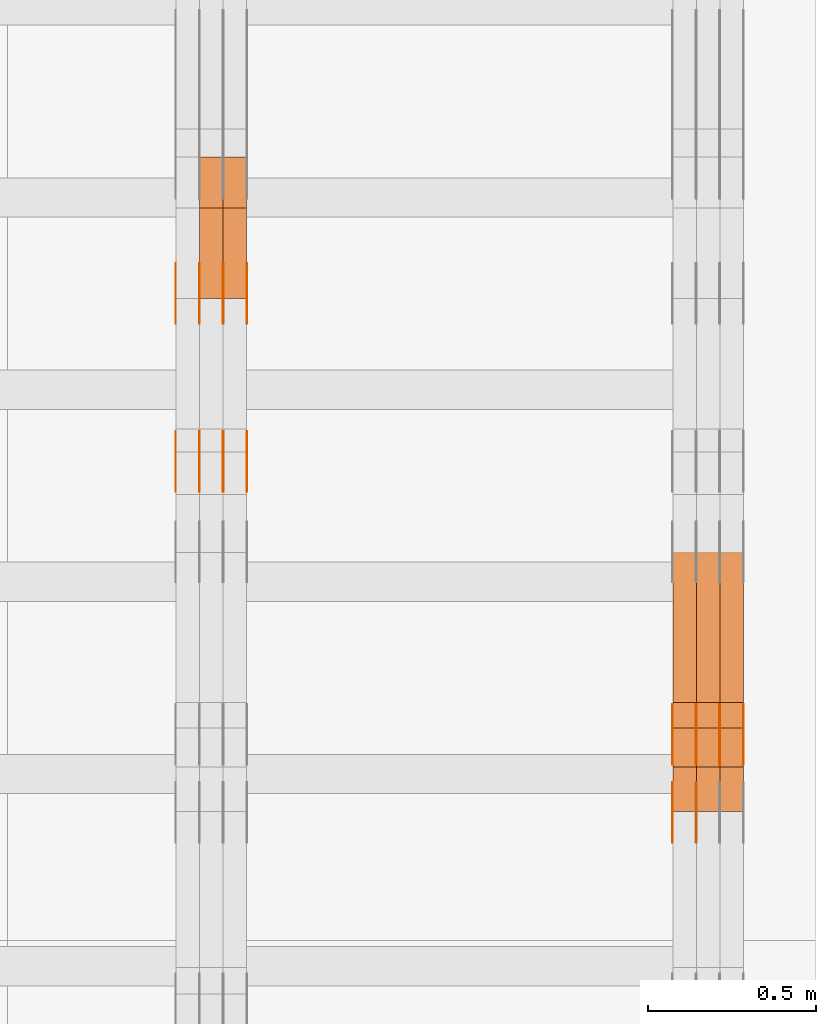
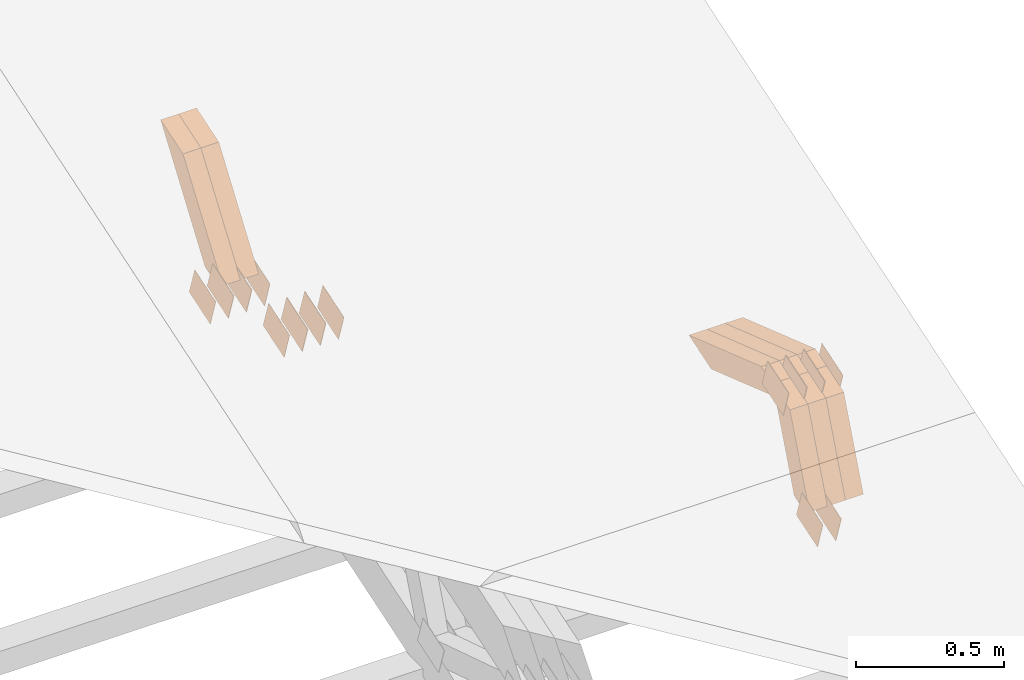
# One storey, part 312 of 385: 28 proxies.
"""IFC2X3 building model written with IfcOpenShell, lengths in millimetres."""

from ifc_helpers import new_model, entity, si_unit, converted_unit, derived_unit, direction, frame, origin, place, context, subcontext, project, spatial, polyline, outline, extrude, source, transform, mapped, material, type_object, type_shapes, element, save


model = new_model("IFC2X3")

# Units and contexts
model_context = context("Model", 3, precision=0.01, world=origin(), true_north=direction((6.12303176911189e-17, 1.0)))
body_context = subcontext(model_context, "Body", "Model", "MODEL_VIEW")
ifc_project = project(units=[si_unit("LENGTHUNIT", "METRE", prefix="MILLI"), si_unit("AREAUNIT", "SQUARE_METRE"), si_unit("VOLUMEUNIT", "CUBIC_METRE"), converted_unit("PLANEANGLEUNIT", "DEGREE", entity("IfcRatioMeasure", 0.0174532925199433), si_unit("PLANEANGLEUNIT", "RADIAN"), dimensions=[0, 0, 0, 0, 0, 0, 0]), si_unit("MASSUNIT", "GRAM", prefix="KILO"), derived_unit("MASSDENSITYUNIT", [(si_unit("MASSUNIT", "GRAM", prefix="KILO"), 1), (si_unit("LENGTHUNIT", "METRE"), -3)]), si_unit("TIMEUNIT", "SECOND"), si_unit("FREQUENCYUNIT", "HERTZ"), si_unit("THERMODYNAMICTEMPERATUREUNIT", "DEGREE_CELSIUS"), derived_unit("THERMALTRANSMITTANCEUNIT", [(si_unit("MASSUNIT", "GRAM", prefix="KILO"), 1), (si_unit("THERMODYNAMICTEMPERATUREUNIT", "KELVIN"), -1), (si_unit("TIMEUNIT", "SECOND"), -3)]), derived_unit("VOLUMETRICFLOWRATEUNIT", [(si_unit("LENGTHUNIT", "METRE"), 3), (si_unit("TIMEUNIT", "SECOND"), -1)]), si_unit("ELECTRICCURRENTUNIT", "AMPERE"), si_unit("ELECTRICVOLTAGEUNIT", "VOLT"), si_unit("POWERUNIT", "WATT"), si_unit("FORCEUNIT", "NEWTON", prefix="KILO"), si_unit("ILLUMINANCEUNIT", "LUX"), si_unit("LUMINOUSFLUXUNIT", "LUMEN"), si_unit("LUMINOUSINTENSITYUNIT", "CANDELA"), derived_unit("USERDEFINED", [(si_unit("MASSUNIT", "GRAM", prefix="KILO"), -1), (si_unit("LENGTHUNIT", "METRE"), -2), (si_unit("TIMEUNIT", "SECOND"), 3), (si_unit("LUMINOUSFLUXUNIT", "LUMEN"), 1)]), derived_unit("LINEARVELOCITYUNIT", [(si_unit("LENGTHUNIT", "METRE"), 1), (si_unit("TIMEUNIT", "SECOND"), -1)]), si_unit("PRESSUREUNIT", "PASCAL"), derived_unit("USERDEFINED", [(si_unit("LENGTHUNIT", "METRE"), -2), (si_unit("MASSUNIT", "GRAM", prefix="KILO"), 1), (si_unit("TIMEUNIT", "SECOND"), -2)])], contexts=[model_context])

# Site, building, storey
site_placement = place(None, origin())
site = spatial("IfcSite", under=ifc_project, at=site_placement, CompositionType="ELEMENT")
building_placement = place(site_placement, origin())
building = spatial("IfcBuilding", under=site, at=building_placement, CompositionType="ELEMENT")
storey_placement = place(building_placement, origin())
storey = spatial("IfcBuildingStorey", under=building, at=storey_placement, Name="Default", CompositionType="ELEMENT", Elevation=0.0)

# Proxies
ifc_material_1 = material(Name="IfcSurfaceStyle #614230")
building_element_proxy_type_1 = type_object("IfcBuildingElementProxyType", PredefinedType="NOTDEFINED", material=ifc_material_1)
shared_shape_1 = source(origin(), body_context, "Body", "SweptSolid", [
    extrude(outline(polyline([(-74.9998801438441, -60.0000306612856), (74.9998747047876, -60.0000306612856), (74.9998707133936, 60.0000306612856), (-74.9998652743371, 60.0000306612856), (-74.9998801438441, -60.0000306612856)])), frame((75.0000206139493, 60.0000306612856, 0.0), z_axis=(0.0, 0.0, 1.0), x_axis=(-1.0, 0.0, 0.0)), (0.0, 0.0, 1.0), 1.29999999999999),
])
type_shapes(building_element_proxy_type_1, [shared_shape_1])
proxy_1_placement = place(building_placement, frame((49721.3, 5987.08381858242, 1121.42116774683), z_axis=(-1.0, 0.0, 0.0), x_axis=(0.0, 0.951056516295124, 0.309016994375039)))
element("IfcBuildingElementProxy", 1, at=proxy_1_placement, inside=storey, type_object=building_element_proxy_type_1, material=ifc_material_1, context=body_context, shape_type="MappedRepresentation", body=[
    mapped(shared_shape_1, transform((0.0, 0.0, 0.0), scale=1.0)),
])
ifc_material_2 = material(Name="IfcSurfaceStyle #614173")
building_element_proxy_type_2 = type_object("IfcBuildingElementProxyType", PredefinedType="NOTDEFINED", material=ifc_material_2)
shared_shape_2 = source(origin(), body_context, "Body", "SweptSolid", [
    extrude(outline(polyline([(-74.9998801438441, -60.0000306612856), (74.9998747047876, -60.0000306612856), (74.9998707133936, 60.0000306612856), (-74.9998652743371, 60.0000306612856), (-74.9998801438441, -60.0000306612856)])), frame((75.0000206139493, 60.0000306612856, 0.0), z_axis=(0.0, 0.0, 1.0), x_axis=(-1.0, 0.0, 0.0)), (0.0, 0.0, 1.0), 1.29999999999999),
])
type_shapes(building_element_proxy_type_2, [shared_shape_2])
proxy_2_placement = place(building_placement, frame((49650.0, 5987.08381858242, 1121.42116774683), z_axis=(-1.0, 0.0, 0.0), x_axis=(0.0, 0.951056516295124, 0.309016994375039)))
element("IfcBuildingElementProxy", 2, at=proxy_2_placement, inside=storey, type_object=building_element_proxy_type_2, material=ifc_material_2, context=body_context, shape_type="MappedRepresentation", body=[
    mapped(shared_shape_2, transform((0.0, 0.0, 0.0), scale=1.0)),
])
ifc_material_3 = material(Name="IfcSurfaceStyle #610012")
building_element_proxy_type_3 = type_object("IfcBuildingElementProxyType", PredefinedType="NOTDEFINED", material=ifc_material_3)
shared_shape_3 = source(origin(), body_context, "Body", "SweptSolid", [
    extrude(outline(polyline([(-74.9998754286253, -60.0000016373506), (74.999860559109, -60.0000016373506), (74.9998754286235, 60.0000016373506), (-74.9998605591072, 60.0000016373506), (-74.9998754286253, -60.0000016373506)])), frame((75.0001009411744, 60.0000279841752, 0.0), z_axis=(0.0, 0.0, 1.0), x_axis=(-1.0, 0.0, 0.0)), (0.0, 0.0, 1.0), 1.3),
])
type_shapes(building_element_proxy_type_3, [shared_shape_3])
proxy_3_placement = place(building_placement, frame((49861.3, 6218.29662915452, 1523.23574463408), z_axis=(-1.0, 0.0, 0.0), x_axis=(0.0, 0.951056516295154, 0.309016994374948)))
element("IfcBuildingElementProxy", 3, at=proxy_3_placement, inside=storey, type_object=building_element_proxy_type_3, material=ifc_material_3, context=body_context, shape_type="MappedRepresentation", body=[
    mapped(shared_shape_3, transform((0.0, 0.0, 0.0), scale=1.0)),
])
ifc_material_4 = material(Name="IfcSurfaceStyle #609955")
building_element_proxy_type_4 = type_object("IfcBuildingElementProxyType", PredefinedType="NOTDEFINED", material=ifc_material_4)
shared_shape_4 = source(origin(), body_context, "Body", "SweptSolid", [
    extrude(outline(polyline([(-74.9998754286253, -60.0000016373506), (74.999860559109, -60.0000016373506), (74.9998754286235, 60.0000016373506), (-74.9998605591072, 60.0000016373506), (-74.9998754286253, -60.0000016373506)])), frame((75.0001009411744, 60.0000279841752, 0.0), z_axis=(0.0, 0.0, 1.0), x_axis=(-1.0, 0.0, 0.0)), (0.0, 0.0, 1.0), 1.3),
])
type_shapes(building_element_proxy_type_4, [shared_shape_4])
proxy_4_placement = place(building_placement, frame((49790.0, 6218.29662915452, 1523.23574463408), z_axis=(-1.0, 0.0, 0.0), x_axis=(0.0, 0.951056516295154, 0.309016994374948)))
element("IfcBuildingElementProxy", 4, at=proxy_4_placement, inside=storey, type_object=building_element_proxy_type_4, material=ifc_material_4, context=body_context, shape_type="MappedRepresentation", body=[
    mapped(shared_shape_4, transform((0.0, 0.0, 0.0), scale=1.0)),
])
ifc_material_5 = material(Name="IfcSurfaceStyle #609898")
building_element_proxy_type_5 = type_object("IfcBuildingElementProxyType", PredefinedType="NOTDEFINED", material=ifc_material_5)
shared_shape_5 = source(origin(), body_context, "Body", "SweptSolid", [
    extrude(outline(polyline([(-74.9998754286253, -60.0000016373506), (74.999860559109, -60.0000016373506), (74.9998754286235, 60.0000016373506), (-74.9998605591072, 60.0000016373506), (-74.9998754286253, -60.0000016373506)])), frame((75.0001009411744, 60.0000279841752, 0.0), z_axis=(0.0, 0.0, 1.0), x_axis=(-1.0, 0.0, 0.0)), (0.0, 0.0, 1.0), 1.3),
])
type_shapes(building_element_proxy_type_5, [shared_shape_5])
proxy_5_placement = place(building_placement, frame((49791.3, 6218.29662915452, 1523.23574463408), z_axis=(-1.0, 0.0, 0.0), x_axis=(0.0, 0.951056516295154, 0.309016994374948)))
element("IfcBuildingElementProxy", 5, at=proxy_5_placement, inside=storey, type_object=building_element_proxy_type_5, material=ifc_material_5, context=body_context, shape_type="MappedRepresentation", body=[
    mapped(shared_shape_5, transform((0.0, 0.0, 0.0), scale=1.0)),
])
ifc_material_6 = material(Name="IfcSurfaceStyle #609841")
building_element_proxy_type_6 = type_object("IfcBuildingElementProxyType", PredefinedType="NOTDEFINED", material=ifc_material_6)
shared_shape_6 = source(origin(), body_context, "Body", "SweptSolid", [
    extrude(outline(polyline([(-74.9998754286253, -60.0000016373506), (74.999860559109, -60.0000016373506), (74.9998754286235, 60.0000016373506), (-74.9998605591072, 60.0000016373506), (-74.9998754286253, -60.0000016373506)])), frame((75.0001009411744, 60.0000279841752, 0.0), z_axis=(0.0, 0.0, 1.0), x_axis=(-1.0, 0.0, 0.0)), (0.0, 0.0, 1.0), 1.29999999999999),
])
type_shapes(building_element_proxy_type_6, [shared_shape_6])
proxy_6_placement = place(building_placement, frame((49720.0, 6218.29662915452, 1523.23574463408), z_axis=(-1.0, 0.0, 0.0), x_axis=(0.0, 0.951056516295154, 0.309016994374948)))
element("IfcBuildingElementProxy", 6, at=proxy_6_placement, inside=storey, type_object=building_element_proxy_type_6, material=ifc_material_6, context=body_context, shape_type="MappedRepresentation", body=[
    mapped(shared_shape_6, transform((0.0, 0.0, 0.0), scale=1.0)),
])
ifc_material_7 = material(Name="IfcSurfaceStyle #609784")
building_element_proxy_type_7 = type_object("IfcBuildingElementProxyType", PredefinedType="NOTDEFINED", material=ifc_material_7)
shared_shape_7 = source(origin(), body_context, "Body", "SweptSolid", [
    extrude(outline(polyline([(-74.9998754286253, -60.0000016373506), (74.999860559109, -60.0000016373506), (74.9998754286235, 60.0000016373506), (-74.9998605591072, 60.0000016373506), (-74.9998754286253, -60.0000016373506)])), frame((75.0001009411744, 60.0000279841752, 0.0), z_axis=(0.0, 0.0, 1.0), x_axis=(-1.0, 0.0, 0.0)), (0.0, 0.0, 1.0), 1.29999999999999),
])
type_shapes(building_element_proxy_type_7, [shared_shape_7])
proxy_7_placement = place(building_placement, frame((49721.3, 6218.29662915452, 1523.23574463408), z_axis=(-1.0, 0.0, 0.0), x_axis=(0.0, 0.951056516295154, 0.309016994374948)))
element("IfcBuildingElementProxy", 7, at=proxy_7_placement, inside=storey, type_object=building_element_proxy_type_7, material=ifc_material_7, context=body_context, shape_type="MappedRepresentation", body=[
    mapped(shared_shape_7, transform((0.0, 0.0, 0.0), scale=1.0)),
])
ifc_material_8 = material(Name="IfcSurfaceStyle #609727")
building_element_proxy_type_8 = type_object("IfcBuildingElementProxyType", PredefinedType="NOTDEFINED", material=ifc_material_8)
shared_shape_8 = source(origin(), body_context, "Body", "SweptSolid", [
    extrude(outline(polyline([(-74.9998754286253, -60.0000016373506), (74.999860559109, -60.0000016373506), (74.9998754286235, 60.0000016373506), (-74.9998605591072, 60.0000016373506), (-74.9998754286253, -60.0000016373506)])), frame((75.0001009411744, 60.0000279841752, 0.0), z_axis=(0.0, 0.0, 1.0), x_axis=(-1.0, 0.0, 0.0)), (0.0, 0.0, 1.0), 1.29999999999999),
])
type_shapes(building_element_proxy_type_8, [shared_shape_8])
proxy_8_placement = place(building_placement, frame((49650.0, 6218.29662915452, 1523.23574463408), z_axis=(-1.0, 0.0, 0.0), x_axis=(0.0, 0.951056516295154, 0.309016994374948)))
element("IfcBuildingElementProxy", 8, at=proxy_8_placement, inside=storey, type_object=building_element_proxy_type_8, material=ifc_material_8, context=body_context, shape_type="MappedRepresentation", body=[
    mapped(shared_shape_8, transform((0.0, 0.0, 0.0), scale=1.0)),
])
ifc_material_9 = material(Name="IfcSurfaceStyle #597016")
building_element_proxy_type_9 = type_object("IfcBuildingElementProxyType", Name="T2-W19 597014", PredefinedType="NOTDEFINED", material=ifc_material_9)
shared_shape_9 = source(origin(), body_context, "Body", "SweptSolid", [
    extrude(outline(polyline([(-234.986199656822, -47.5000587840676), (221.224626701627, -47.5000587840676), (219.29748584664, -9.04449542012076e-05), (156.014457007826, 47.5001040065446), (-361.550369899272, 47.5001040065447), (-234.986199656822, -47.5000587840676)])), frame((221.224626701627, 47.5001108598228, 0.0), z_axis=(0.0, 0.0, 1.0), x_axis=(-1.0, 0.0, 0.0)), (0.0, 0.0, 1.0), 70.0),
])
type_shapes(building_element_proxy_type_9, [shared_shape_9])
proxy_9_placement = place(building_placement, frame((49860.0, 6342.4042570111, 1541.63383639481), z_axis=(-1.0, 0.0, 0.0), x_axis=(0.0, 0.9461301511345, -0.323786561046329)))
element("IfcBuildingElementProxy", 9, at=proxy_9_placement, inside=storey, type_object=building_element_proxy_type_9, material=ifc_material_9, Name="T2-W19", context=body_context, shape_type="MappedRepresentation", body=[
    mapped(shared_shape_9, transform((0.0, 0.0, 0.0), scale=1.0)),
])
ifc_material_10 = material(Name="IfcSurfaceStyle #596950")
building_element_proxy_type_10 = type_object("IfcBuildingElementProxyType", Name="T2-W19 596948", PredefinedType="NOTDEFINED", material=ifc_material_10)
shared_shape_10 = source(origin(), body_context, "Body", "SweptSolid", [
    extrude(outline(polyline([(-234.986199656822, -47.5000587840676), (221.224626701627, -47.5000587840676), (219.29748584664, -9.04449542012076e-05), (156.014457007826, 47.5001040065446), (-361.550369899272, 47.5001040065447), (-234.986199656822, -47.5000587840676)])), frame((221.224626701627, 47.5001108598228, 0.0), z_axis=(0.0, 0.0, 1.0), x_axis=(-1.0, 0.0, 0.0)), (0.0, 0.0, 1.0), 70.0),
])
type_shapes(building_element_proxy_type_10, [shared_shape_10])
proxy_10_placement = place(building_placement, frame((49790.0, 6342.4042570111, 1541.63383639481), z_axis=(-1.0, 0.0, 0.0), x_axis=(0.0, 0.9461301511345, -0.323786561046329)))
element("IfcBuildingElementProxy", 10, at=proxy_10_placement, inside=storey, type_object=building_element_proxy_type_10, material=ifc_material_10, Name="T2-W19", context=body_context, shape_type="MappedRepresentation", body=[
    mapped(shared_shape_10, transform((0.0, 0.0, 0.0), scale=1.0)),
])
ifc_material_11 = material(Name="IfcSurfaceStyle #596884")
building_element_proxy_type_11 = type_object("IfcBuildingElementProxyType", Name="T2-W19 596882", PredefinedType="NOTDEFINED", material=ifc_material_11)
shared_shape_11 = source(origin(), body_context, "Body", "SweptSolid", [
    extrude(outline(polyline([(-234.986199656822, -47.5000587840676), (221.224626701627, -47.5000587840676), (219.29748584664, -9.04449542012076e-05), (156.014457007826, 47.5001040065446), (-361.550369899272, 47.5001040065447), (-234.986199656822, -47.5000587840676)])), frame((221.224626701627, 47.5001108598228, 0.0), z_axis=(0.0, 0.0, 1.0), x_axis=(-1.0, 0.0, 0.0)), (0.0, 0.0, 1.0), 70.0),
])
type_shapes(building_element_proxy_type_11, [shared_shape_11])
proxy_11_placement = place(building_placement, frame((49720.0, 6342.4042570111, 1541.63383639481), z_axis=(-1.0, 0.0, 0.0), x_axis=(0.0, 0.9461301511345, -0.323786561046329)))
element("IfcBuildingElementProxy", 11, at=proxy_11_placement, inside=storey, type_object=building_element_proxy_type_11, material=ifc_material_11, Name="T2-W19", context=body_context, shape_type="MappedRepresentation", body=[
    mapped(shared_shape_11, transform((0.0, 0.0, 0.0), scale=1.0)),
])
ifc_material_12 = material(Name="IfcSurfaceStyle #596620")
building_element_proxy_type_12 = type_object("IfcBuildingElementProxyType", Name="T2-W46 596618", PredefinedType="NOTDEFINED", material=ifc_material_12)
shared_shape_12 = source(origin(), body_context, "Body", "SweptSolid", [
    extrude(outline(polyline([(-272.224583017384, -47.5002947748381), (128.798007350946, -47.5002947748382), (167.560249082673, 0.000339032424879266), (170.567132940603, 47.500741369691), (-194.700806356838, 47.4995091475604), (-272.224583017384, -47.5002947748381)])), frame((170.567293182179, 47.5001659655231, 0.0), z_axis=(0.0, 0.0, 1.0), x_axis=(-1.0, 3.37347464168628e-06, 0.0)), (0.0, 0.0, 1.0), 70.0),
])
type_shapes(building_element_proxy_type_12, [shared_shape_12])
proxy_12_placement = place(building_placement, frame((49860.0, 6080.046875, 1117.66674804688), z_axis=(-1.0, 0.0, 0.0), x_axis=(0.0, 0.361885618189232, 0.93222250527854)))
element("IfcBuildingElementProxy", 12, at=proxy_12_placement, inside=storey, type_object=building_element_proxy_type_12, material=ifc_material_12, Name="T2-W46", context=body_context, shape_type="MappedRepresentation", body=[
    mapped(shared_shape_12, transform((0.0, 0.0, 0.0), scale=1.0)),
])
ifc_material_13 = material(Name="IfcSurfaceStyle #596554")
building_element_proxy_type_13 = type_object("IfcBuildingElementProxyType", Name="T2-W46 596552", PredefinedType="NOTDEFINED", material=ifc_material_13)
shared_shape_13 = source(origin(), body_context, "Body", "SweptSolid", [
    extrude(outline(polyline([(-272.224583017384, -47.5002947748381), (128.798007350946, -47.5002947748382), (167.560249082673, 0.000339032424879266), (170.567132940603, 47.500741369691), (-194.700806356838, 47.4995091475604), (-272.224583017384, -47.5002947748381)])), frame((170.567293182179, 47.5001659655231, 0.0), z_axis=(0.0, 0.0, 1.0), x_axis=(-1.0, 3.37347464168628e-06, 0.0)), (0.0, 0.0, 1.0), 70.0),
])
type_shapes(building_element_proxy_type_13, [shared_shape_13])
proxy_13_placement = place(building_placement, frame((49790.0, 6080.046875, 1117.66674804688), z_axis=(-1.0, 0.0, 0.0), x_axis=(0.0, 0.361885618189232, 0.93222250527854)))
element("IfcBuildingElementProxy", 13, at=proxy_13_placement, inside=storey, type_object=building_element_proxy_type_13, material=ifc_material_13, Name="T2-W46", context=body_context, shape_type="MappedRepresentation", body=[
    mapped(shared_shape_13, transform((0.0, 0.0, 0.0), scale=1.0)),
])
ifc_material_14 = material(Name="IfcSurfaceStyle #596488")
building_element_proxy_type_14 = type_object("IfcBuildingElementProxyType", Name="T2-W46 596486", PredefinedType="NOTDEFINED", material=ifc_material_14)
shared_shape_14 = source(origin(), body_context, "Body", "SweptSolid", [
    extrude(outline(polyline([(-272.224583017384, -47.5002947748381), (128.798007350946, -47.5002947748382), (167.560249082673, 0.000339032424879266), (170.567132940603, 47.500741369691), (-194.700806356838, 47.4995091475604), (-272.224583017384, -47.5002947748381)])), frame((170.567293182179, 47.5001659655231, 0.0), z_axis=(0.0, 0.0, 1.0), x_axis=(-1.0, 3.37347464168628e-06, 0.0)), (0.0, 0.0, 1.0), 70.0),
])
type_shapes(building_element_proxy_type_14, [shared_shape_14])
proxy_14_placement = place(building_placement, frame((49720.0, 6080.046875, 1117.66674804688), z_axis=(-1.0, 0.0, 0.0), x_axis=(0.0, 0.361885618189232, 0.93222250527854)))
element("IfcBuildingElementProxy", 14, at=proxy_14_placement, inside=storey, type_object=building_element_proxy_type_14, material=ifc_material_14, Name="T2-W46", context=body_context, shape_type="MappedRepresentation", body=[
    mapped(shared_shape_14, transform((0.0, 0.0, 0.0), scale=1.0)),
])
ifc_material_15 = material(Name="IfcSurfaceStyle #586524")
building_element_proxy_type_15 = type_object("IfcBuildingElementProxyType", PredefinedType="NOTDEFINED", material=ifc_material_15)
shared_shape_15 = source(origin(), body_context, "Body", "SweptSolid", [
    extrude(outline(polyline([(-74.9998565677169, -60.0000596852269), (74.9998794200137, -60.0000596852269), (74.9998565677151, 60.0000596852269), (-74.9998794200119, 60.0000596852269), (-74.9998565677169, -60.0000596852269)])), frame((74.9998794200137, 60.0000596852269, 0.0), z_axis=(0.0, 0.0, 1.0), x_axis=(-1.0, 0.0, 0.0)), (0.0, 0.0, 1.0), 1.3),
])
type_shapes(building_element_proxy_type_15, [shared_shape_15])
proxy_15_placement = place(building_placement, frame((48386.3, 7527.6269081625, 1621.97418552253), z_axis=(-1.0, 0.0, 0.0), x_axis=(0.0, 0.951056516295124, 0.309016994375039)))
element("IfcBuildingElementProxy", 15, at=proxy_15_placement, inside=storey, type_object=building_element_proxy_type_15, material=ifc_material_15, context=body_context, shape_type="MappedRepresentation", body=[
    mapped(shared_shape_15, transform((0.0, 0.0, 0.0), scale=1.0)),
])
ifc_material_16 = material(Name="IfcSurfaceStyle #586467")
building_element_proxy_type_16 = type_object("IfcBuildingElementProxyType", PredefinedType="NOTDEFINED", material=ifc_material_16)
shared_shape_16 = source(origin(), body_context, "Body", "SweptSolid", [
    extrude(outline(polyline([(-74.9998565677169, -60.0000596852269), (74.9998794200137, -60.0000596852269), (74.9998565677151, 60.0000596852269), (-74.9998794200119, 60.0000596852269), (-74.9998565677169, -60.0000596852269)])), frame((74.9998794200137, 60.0000596852269, 0.0), z_axis=(0.0, 0.0, 1.0), x_axis=(-1.0, 0.0, 0.0)), (0.0, 0.0, 1.0), 1.3),
])
type_shapes(building_element_proxy_type_16, [shared_shape_16])
proxy_16_placement = place(building_placement, frame((48315.0, 7527.6269081625, 1621.97418552253), z_axis=(-1.0, 0.0, 0.0), x_axis=(0.0, 0.951056516295124, 0.309016994375039)))
element("IfcBuildingElementProxy", 16, at=proxy_16_placement, inside=storey, type_object=building_element_proxy_type_16, material=ifc_material_16, context=body_context, shape_type="MappedRepresentation", body=[
    mapped(shared_shape_16, transform((0.0, 0.0, 0.0), scale=1.0)),
])
ifc_material_17 = material(Name="IfcSurfaceStyle #586410")
building_element_proxy_type_17 = type_object("IfcBuildingElementProxyType", PredefinedType="NOTDEFINED", material=ifc_material_17)
shared_shape_17 = source(origin(), body_context, "Body", "SweptSolid", [
    extrude(outline(polyline([(-74.9998565677169, -60.0000596852269), (74.9998794200137, -60.0000596852269), (74.9998565677151, 60.0000596852269), (-74.9998794200119, 60.0000596852269), (-74.9998565677169, -60.0000596852269)])), frame((74.9998794200137, 60.0000596852269, 0.0), z_axis=(0.0, 0.0, 1.0), x_axis=(-1.0, 0.0, 0.0)), (0.0, 0.0, 1.0), 1.3),
])
type_shapes(building_element_proxy_type_17, [shared_shape_17])
proxy_17_placement = place(building_placement, frame((48316.3, 7527.6269081625, 1621.97418552253), z_axis=(-1.0, 0.0, 0.0), x_axis=(0.0, 0.951056516295124, 0.309016994375039)))
element("IfcBuildingElementProxy", 17, at=proxy_17_placement, inside=storey, type_object=building_element_proxy_type_17, material=ifc_material_17, context=body_context, shape_type="MappedRepresentation", body=[
    mapped(shared_shape_17, transform((0.0, 0.0, 0.0), scale=1.0)),
])
ifc_material_18 = material(Name="IfcSurfaceStyle #586353")
building_element_proxy_type_18 = type_object("IfcBuildingElementProxyType", PredefinedType="NOTDEFINED", material=ifc_material_18)
shared_shape_18 = source(origin(), body_context, "Body", "SweptSolid", [
    extrude(outline(polyline([(-74.9998565677169, -60.0000596852269), (74.9998794200137, -60.0000596852269), (74.9998565677151, 60.0000596852269), (-74.9998794200119, 60.0000596852269), (-74.9998565677169, -60.0000596852269)])), frame((74.9998794200137, 60.0000596852269, 0.0), z_axis=(0.0, 0.0, 1.0), x_axis=(-1.0, 0.0, 0.0)), (0.0, 0.0, 1.0), 1.29999999999999),
])
type_shapes(building_element_proxy_type_18, [shared_shape_18])
proxy_18_placement = place(building_placement, frame((48245.0, 7527.6269081625, 1621.97418552253), z_axis=(-1.0, 0.0, 0.0), x_axis=(0.0, 0.951056516295124, 0.309016994375039)))
element("IfcBuildingElementProxy", 18, at=proxy_18_placement, inside=storey, type_object=building_element_proxy_type_18, material=ifc_material_18, context=body_context, shape_type="MappedRepresentation", body=[
    mapped(shared_shape_18, transform((0.0, 0.0, 0.0), scale=1.0)),
])
ifc_material_19 = material(Name="IfcSurfaceStyle #586296")
building_element_proxy_type_19 = type_object("IfcBuildingElementProxyType", PredefinedType="NOTDEFINED", material=ifc_material_19)
shared_shape_19 = source(origin(), body_context, "Body", "SweptSolid", [
    extrude(outline(polyline([(-74.9998565677169, -60.0000596852269), (74.9998794200137, -60.0000596852269), (74.9998565677151, 60.0000596852269), (-74.9998794200119, 60.0000596852269), (-74.9998565677169, -60.0000596852269)])), frame((74.9998794200137, 60.0000596852269, 0.0), z_axis=(0.0, 0.0, 1.0), x_axis=(-1.0, 0.0, 0.0)), (0.0, 0.0, 1.0), 1.29999999999999),
])
type_shapes(building_element_proxy_type_19, [shared_shape_19])
proxy_19_placement = place(building_placement, frame((48246.3, 7527.6269081625, 1621.97418552253), z_axis=(-1.0, 0.0, 0.0), x_axis=(0.0, 0.951056516295124, 0.309016994375039)))
element("IfcBuildingElementProxy", 19, at=proxy_19_placement, inside=storey, type_object=building_element_proxy_type_19, material=ifc_material_19, context=body_context, shape_type="MappedRepresentation", body=[
    mapped(shared_shape_19, transform((0.0, 0.0, 0.0), scale=1.0)),
])
ifc_material_20 = material(Name="IfcSurfaceStyle #586239")
building_element_proxy_type_20 = type_object("IfcBuildingElementProxyType", PredefinedType="NOTDEFINED", material=ifc_material_20)
shared_shape_20 = source(origin(), body_context, "Body", "SweptSolid", [
    extrude(outline(polyline([(-74.9998565677169, -60.0000596852269), (74.9998794200137, -60.0000596852269), (74.9998565677151, 60.0000596852269), (-74.9998794200119, 60.0000596852269), (-74.9998565677169, -60.0000596852269)])), frame((74.9998794200137, 60.0000596852269, 0.0), z_axis=(0.0, 0.0, 1.0), x_axis=(-1.0, 0.0, 0.0)), (0.0, 0.0, 1.0), 1.29999999999999),
])
type_shapes(building_element_proxy_type_20, [shared_shape_20])
proxy_20_placement = place(building_placement, frame((48175.0, 7527.6269081625, 1621.97418552253), z_axis=(-1.0, 0.0, 0.0), x_axis=(0.0, 0.951056516295124, 0.309016994375039)))
element("IfcBuildingElementProxy", 20, at=proxy_20_placement, inside=storey, type_object=building_element_proxy_type_20, material=ifc_material_20, context=body_context, shape_type="MappedRepresentation", body=[
    mapped(shared_shape_20, transform((0.0, 0.0, 0.0), scale=1.0)),
])
ifc_material_21 = material(Name="IfcSurfaceStyle #576264")
building_element_proxy_type_21 = type_object("IfcBuildingElementProxyType", PredefinedType="NOTDEFINED", material=ifc_material_21)
shared_shape_21 = source(origin(), body_context, "Body", "SweptSolid", [
    extrude(outline(polyline([(-74.9998565677233, -60.0000596852342), (74.9998794200074, -60.0000596852342), (74.9998565677233, 60.0000596852342), (-74.9998794200074, 60.0000596852342), (-74.9998565677233, -60.0000596852342)])), frame((74.9998794200073, 60.0000596852342, 0.0), z_axis=(0.0, 0.0, 1.0), x_axis=(-1.0, 0.0, 0.0)), (0.0, 0.0, 1.0), 1.3),
])
type_shapes(building_element_proxy_type_21, [shared_shape_21])
proxy_21_placement = place(building_placement, frame((48386.3, 7029.15620503752, 1786.70025974129), z_axis=(-1.0, 0.0, 0.0), x_axis=(0.0, 0.951056516295154, 0.309016994374948)))
element("IfcBuildingElementProxy", 21, at=proxy_21_placement, inside=storey, type_object=building_element_proxy_type_21, material=ifc_material_21, context=body_context, shape_type="MappedRepresentation", body=[
    mapped(shared_shape_21, transform((0.0, 0.0, 0.0), scale=1.0)),
])
ifc_material_22 = material(Name="IfcSurfaceStyle #576207")
building_element_proxy_type_22 = type_object("IfcBuildingElementProxyType", PredefinedType="NOTDEFINED", material=ifc_material_22)
shared_shape_22 = source(origin(), body_context, "Body", "SweptSolid", [
    extrude(outline(polyline([(-74.9998565677233, -60.0000596852342), (74.9998794200074, -60.0000596852342), (74.9998565677233, 60.0000596852342), (-74.9998794200074, 60.0000596852342), (-74.9998565677233, -60.0000596852342)])), frame((74.9998794200073, 60.0000596852342, 0.0), z_axis=(0.0, 0.0, 1.0), x_axis=(-1.0, 0.0, 0.0)), (0.0, 0.0, 1.0), 1.3),
])
type_shapes(building_element_proxy_type_22, [shared_shape_22])
proxy_22_placement = place(building_placement, frame((48315.0, 7029.15620503752, 1786.70025974129), z_axis=(-1.0, 0.0, 0.0), x_axis=(0.0, 0.951056516295154, 0.309016994374948)))
element("IfcBuildingElementProxy", 22, at=proxy_22_placement, inside=storey, type_object=building_element_proxy_type_22, material=ifc_material_22, context=body_context, shape_type="MappedRepresentation", body=[
    mapped(shared_shape_22, transform((0.0, 0.0, 0.0), scale=1.0)),
])
ifc_material_23 = material(Name="IfcSurfaceStyle #576150")
building_element_proxy_type_23 = type_object("IfcBuildingElementProxyType", PredefinedType="NOTDEFINED", material=ifc_material_23)
shared_shape_23 = source(origin(), body_context, "Body", "SweptSolid", [
    extrude(outline(polyline([(-74.9998565677233, -60.0000596852342), (74.9998794200074, -60.0000596852342), (74.9998565677233, 60.0000596852342), (-74.9998794200074, 60.0000596852342), (-74.9998565677233, -60.0000596852342)])), frame((74.9998794200073, 60.0000596852342, 0.0), z_axis=(0.0, 0.0, 1.0), x_axis=(-1.0, 0.0, 0.0)), (0.0, 0.0, 1.0), 1.3),
])
type_shapes(building_element_proxy_type_23, [shared_shape_23])
proxy_23_placement = place(building_placement, frame((48316.3, 7029.15620503752, 1786.70025974129), z_axis=(-1.0, 0.0, 0.0), x_axis=(0.0, 0.951056516295154, 0.309016994374948)))
element("IfcBuildingElementProxy", 23, at=proxy_23_placement, inside=storey, type_object=building_element_proxy_type_23, material=ifc_material_23, context=body_context, shape_type="MappedRepresentation", body=[
    mapped(shared_shape_23, transform((0.0, 0.0, 0.0), scale=1.0)),
])
ifc_material_24 = material(Name="IfcSurfaceStyle #576093")
building_element_proxy_type_24 = type_object("IfcBuildingElementProxyType", PredefinedType="NOTDEFINED", material=ifc_material_24)
shared_shape_24 = source(origin(), body_context, "Body", "SweptSolid", [
    extrude(outline(polyline([(-74.9998565677233, -60.0000596852342), (74.9998794200074, -60.0000596852342), (74.9998565677233, 60.0000596852342), (-74.9998794200074, 60.0000596852342), (-74.9998565677233, -60.0000596852342)])), frame((74.9998794200073, 60.0000596852342, 0.0), z_axis=(0.0, 0.0, 1.0), x_axis=(-1.0, 0.0, 0.0)), (0.0, 0.0, 1.0), 1.29999999999999),
])
type_shapes(building_element_proxy_type_24, [shared_shape_24])
proxy_24_placement = place(building_placement, frame((48245.0, 7029.15620503752, 1786.70025974129), z_axis=(-1.0, 0.0, 0.0), x_axis=(0.0, 0.951056516295154, 0.309016994374948)))
element("IfcBuildingElementProxy", 24, at=proxy_24_placement, inside=storey, type_object=building_element_proxy_type_24, material=ifc_material_24, context=body_context, shape_type="MappedRepresentation", body=[
    mapped(shared_shape_24, transform((0.0, 0.0, 0.0), scale=1.0)),
])
ifc_material_25 = material(Name="IfcSurfaceStyle #576036")
building_element_proxy_type_25 = type_object("IfcBuildingElementProxyType", PredefinedType="NOTDEFINED", material=ifc_material_25)
shared_shape_25 = source(origin(), body_context, "Body", "SweptSolid", [
    extrude(outline(polyline([(-74.9998565677233, -60.0000596852342), (74.9998794200074, -60.0000596852342), (74.9998565677233, 60.0000596852342), (-74.9998794200074, 60.0000596852342), (-74.9998565677233, -60.0000596852342)])), frame((74.9998794200073, 60.0000596852342, 0.0), z_axis=(0.0, 0.0, 1.0), x_axis=(-1.0, 0.0, 0.0)), (0.0, 0.0, 1.0), 1.29999999999999),
])
type_shapes(building_element_proxy_type_25, [shared_shape_25])
proxy_25_placement = place(building_placement, frame((48246.3, 7029.15620503752, 1786.70025974129), z_axis=(-1.0, 0.0, 0.0), x_axis=(0.0, 0.951056516295154, 0.309016994374948)))
element("IfcBuildingElementProxy", 25, at=proxy_25_placement, inside=storey, type_object=building_element_proxy_type_25, material=ifc_material_25, context=body_context, shape_type="MappedRepresentation", body=[
    mapped(shared_shape_25, transform((0.0, 0.0, 0.0), scale=1.0)),
])
ifc_material_26 = material(Name="IfcSurfaceStyle #575979")
building_element_proxy_type_26 = type_object("IfcBuildingElementProxyType", PredefinedType="NOTDEFINED", material=ifc_material_26)
shared_shape_26 = source(origin(), body_context, "Body", "SweptSolid", [
    extrude(outline(polyline([(-74.9998565677233, -60.0000596852342), (74.9998794200074, -60.0000596852342), (74.9998565677233, 60.0000596852342), (-74.9998794200074, 60.0000596852342), (-74.9998565677233, -60.0000596852342)])), frame((74.9998794200073, 60.0000596852342, 0.0), z_axis=(0.0, 0.0, 1.0), x_axis=(-1.0, 0.0, 0.0)), (0.0, 0.0, 1.0), 1.29999999999999),
])
type_shapes(building_element_proxy_type_26, [shared_shape_26])
proxy_26_placement = place(building_placement, frame((48175.0, 7029.15620503752, 1786.70025974129), z_axis=(-1.0, 0.0, 0.0), x_axis=(0.0, 0.951056516295154, 0.309016994374948)))
element("IfcBuildingElementProxy", 26, at=proxy_26_placement, inside=storey, type_object=building_element_proxy_type_26, material=ifc_material_26, context=body_context, shape_type="MappedRepresentation", body=[
    mapped(shared_shape_26, transform((0.0, 0.0, 0.0), scale=1.0)),
])
ifc_material_27 = material(Name="IfcSurfaceStyle #563772")
building_element_proxy_type_27 = type_object("IfcBuildingElementProxyType", Name="T1-W17 563770", PredefinedType="NOTDEFINED", material=ifc_material_27)
shared_shape_27 = source(origin(), body_context, "Body", "SweptSolid", [
    extrude(outline(polyline([(-364.271754334175, -47.5002955168173), (154.762247185537, -47.5002955168173), (218.32500198375, 4.1746158945366e-05), (228.330650189718, 47.5002746437378), (-237.14614502483, 47.5002746437378), (-364.271754334175, -47.5002955168173)])), frame((228.330650189718, 47.5002746437378, 0.0), z_axis=(0.0, 0.0, 1.0), x_axis=(-1.0, 0.0, 0.0)), (0.0, 0.0, 1.0), 70.0),
])
type_shapes(building_element_proxy_type_27, [shared_shape_27])
proxy_27_placement = place(building_placement, frame((48385.0, 7603.59179687501, 1617.27880859375), z_axis=(-1.0, 0.0, 0.0), x_axis=(0.0, 0.576852646364743, 0.816848226038346)))
element("IfcBuildingElementProxy", 27, at=proxy_27_placement, inside=storey, type_object=building_element_proxy_type_27, material=ifc_material_27, Name="T1-W17", context=body_context, shape_type="MappedRepresentation", body=[
    mapped(shared_shape_27, transform((0.0, 0.0, 0.0), scale=1.0)),
])
ifc_material_28 = material(Name="IfcSurfaceStyle #563706")
building_element_proxy_type_28 = type_object("IfcBuildingElementProxyType", Name="T1-W17 563704", PredefinedType="NOTDEFINED", material=ifc_material_28)
shared_shape_28 = source(origin(), body_context, "Body", "SweptSolid", [
    extrude(outline(polyline([(-364.271754334175, -47.5002955168173), (154.762247185537, -47.5002955168173), (218.32500198375, 4.1746158945366e-05), (228.330650189718, 47.5002746437378), (-237.14614502483, 47.5002746437378), (-364.271754334175, -47.5002955168173)])), frame((228.330650189718, 47.5002746437378, 0.0), z_axis=(0.0, 0.0, 1.0), x_axis=(-1.0, 0.0, 0.0)), (0.0, 0.0, 1.0), 70.0),
])
type_shapes(building_element_proxy_type_28, [shared_shape_28])
proxy_28_placement = place(building_placement, frame((48315.0, 7603.59179687501, 1617.27880859375), z_axis=(-1.0, 0.0, 0.0), x_axis=(0.0, 0.576852646364743, 0.816848226038346)))
element("IfcBuildingElementProxy", 28, at=proxy_28_placement, inside=storey, type_object=building_element_proxy_type_28, material=ifc_material_28, Name="T1-W17", context=body_context, shape_type="MappedRepresentation", body=[
    mapped(shared_shape_28, transform((0.0, 0.0, 0.0), scale=1.0)),
])

save(model, "model.ifc")
